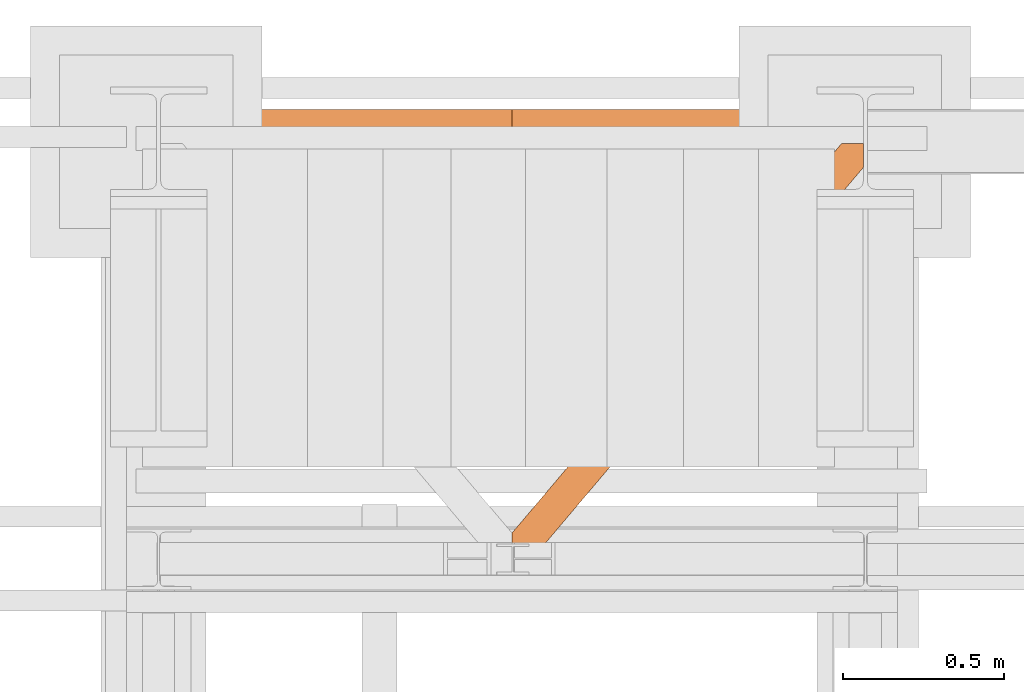
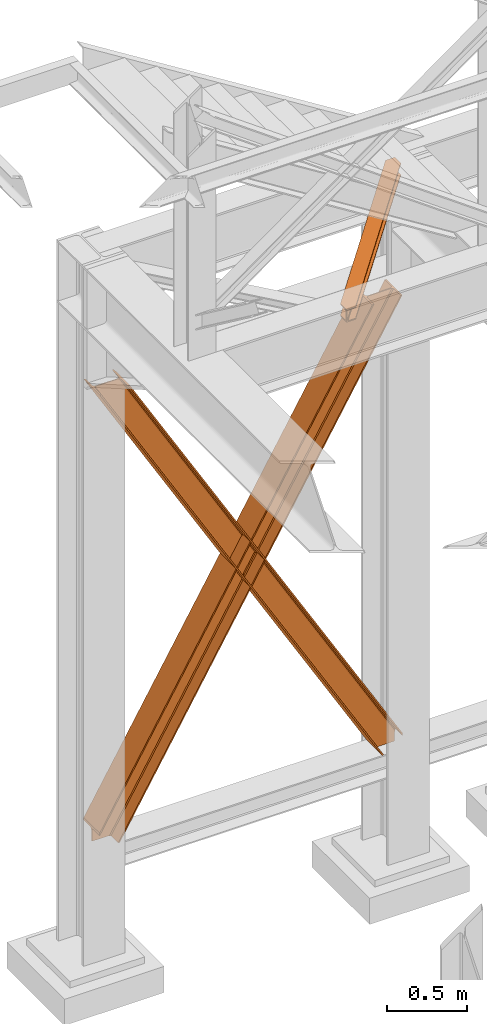
# One storey, part 134 of 208: 3 proxies.
"""IFC2X3 building model written with IfcOpenShell, lengths in millimetres."""

from ifc_helpers import new_model, entity, si_unit, converted_unit, frame, origin, origin_with_axes, place, context, subcontext, project, spatial, faceted_brep, element, save


model = new_model("IFC2X3")

# Units and contexts
model_context = context("Model", 3, precision=1e-05, world=origin())
plan_context = context("Plan", 3, precision=1e-05, world=origin())
body_context = subcontext(model_context, "Body", "Model", "MODEL_VIEW")
ifc_project = project(units=[si_unit("LENGTHUNIT", "METRE", prefix="MILLI"), converted_unit("PLANEANGLEUNIT", "DEGREE", entity("IfcPlaneAngleMeasure", 0.0174532925199433), si_unit("PLANEANGLEUNIT", "RADIAN"), dimensions=[0, 0, 0, 0, 0, 0, 0]), si_unit("AREAUNIT", "SQUARE_METRE"), si_unit("VOLUMEUNIT", "CUBIC_METRE")], contexts=[model_context, plan_context])

# Building, storey
building_placement = place(None, origin())
building = spatial("IfcBuilding", under=ifc_project, at=building_placement, CompositionType="COMPLEX")
storey_placement = place(building_placement, origin_with_axes())
storey = spatial("IfcBuildingStorey", under=building, at=storey_placement, Name="Geschoss", CompositionType="ELEMENT")

# Proxies
proxy_1_placement = place(storey_placement, frame((-3300.167549460099, -12562.57439501764, 734.9900149335328), z_axis=(0.0, 0.0, 1.0), x_axis=(1.0, 0.0, 0.0)))
element("IfcBuildingElementProxy", 1, at=proxy_1_placement, inside=storey, context=body_context, shape_type="Brep", body=[
    faceted_brep([(2187.432517936612, 0.01000000000021828, 120.8497915510924), (216.8471928951321, 0.01000000000021828, 3468.009977913908), (216.8471928951321, 200.0100029802325, 3468.009977913908), (2187.432517936612, 200.0100029802325, 120.8497915510924), (2187.432517936612, 200.0100029802325, 120.8497915510924), (216.8471928951321, 200.0100029802325, 3468.009977913908), (205.4347121912169, 200.0100029802325, 3468.009977913908), (2187.432517936612, 200.0100029802325, 101.4682129393398), (2187.432517936612, 200.0100029802325, 101.4682129393398), (205.4347121912169, 200.0100029802325, 3468.009977913908), (205.4347036882541, 121.2600035762789, 3468.009977913908), (2187.432517936951, 121.2600035762789, 101.4681984983711), (2187.432517936951, 121.2600035762789, 101.4681984983711), (205.4347036882541, 121.2600035762789, 3468.009977913908), (203.306794806967, 111.9441915473344, 3468.009977913909), (2187.432602958225, 111.9441915473344, 97.85427409430258), (2187.432602958225, 111.9441915473344, 97.85427409430258), (203.306794806967, 111.9441915473344, 3468.009977913909), (195.5238886772499, 105.1245498640838, 3468.009977913908), (2187.432517936612, 105.1245498640838, 84.63689245399041), (2187.432517936612, 105.1245498640838, 84.63689245399041), (195.5238886772499, 105.1245498640838, 3468.009977913908), (184.892235020021, 103.2600015571716, 3468.009977913908), (2187.432517936612, 103.2600015571716, 66.58142866151923), (2187.432517936612, 103.2600015571716, 0.009999999999990905), (2187.432517936612, 103.2600015571716, 66.58142866151923), (184.892235020021, 103.2600015571716, 3468.009977913908), (31.96494937214857, 103.2600015571716, 3468.009977913908), (2073.723887154785, 103.2600015571716, 0.01000000000021828), (2073.723887154785, 103.2600015571716, 0.01000000000021828), (31.96494937214857, 103.2600015571716, 3468.009977913908), (21.33329571491913, 105.1245498640838, 3468.009977913908), (2063.093996904378, 105.1245498640838, 0.01000000000010459), (2063.093996904378, 105.1245498640838, 0.01000000000010459), (21.33329571491913, 105.1245498640838, 3468.009977913908), (13.55038958520254, 111.9441915473344, 3468.009977913908), (2055.312379673187, 111.9441915473344, 0.009999999999763531), (2055.312379673187, 111.9441915473344, 0.009999999999763531), (13.55038958520254, 111.9441915473344, 3468.009977913908), (11.42248070391588, 121.2600035762789, 3468.009977913907), (2053.184822892689, 121.2600035762789, 0.009999999999763531), (2053.184822892689, 121.2600035762789, 0.009999999999763531), (11.42248070391588, 121.2600035762789, 3468.009977913907), (11.42248070391634, 200.0100029802325, 3468.009977913907), (2053.184822892689, 200.0100029802325, 0.009999999999763531), (2053.184822892689, 200.0100029802325, 0.009999999999763531), (11.42248070391634, 200.0100029802325, 3468.009977913907), (0.01000000000021828, 200.0100029802325, 3468.009977913908), (2041.774228435659, 200.0100029802325, 0.009999999999990905), (2041.774228435659, 200.0100029802325, 0.009999999999990905), (0.01000000000021828, 200.0100029802325, 3468.009977913908), (0.01000000000021828, 0.01000000000021828, 3468.009977913908), (2041.774228435659, 0.01000000000021828, 0.009999999999990905), (2041.774228435659, 0.01000000000021828, 0.009999999999990905), (0.01000000000021828, 0.01000000000021828, 3468.009977913908), (11.42248070391679, 0.01000000000021828, 3468.009977913908), (2053.184822892689, 0.01000000000021828, 0.009999999999877218), (2053.184822892689, 0.01000000000021828, 0.009999999999877218), (11.42248070391679, 0.01000000000021828, 3468.009977913908), (11.42248070391634, 78.75999940395377, 3468.009977913907), (2053.184822892689, 78.75999940395377, 0.009999999999763531), (2053.184822892689, 78.75999940395377, 0.009999999999763531), (11.42248070391634, 78.75999940395377, 3468.009977913907), (13.55038958520254, 88.07581143290008, 3468.009977913908), (2055.312379673187, 88.07581143289826, 0.009999999999763531), (2055.312379673187, 88.07581143289826, 0.009999999999763531), (13.55038958520254, 88.07581143290008, 3468.009977913908), (21.33329571491913, 94.89545311614893, 3468.009977913908), (2063.093996904379, 94.89545311614893, 0.009999999999763531), (2063.093996904379, 94.89545311614893, 0.009999999999763531), (21.33329571491913, 94.89545311614893, 3468.009977913908), (31.96494937214857, 96.76000142306111, 3468.009977913908), (2073.723887154785, 96.76000142306111, 0.01000000000021828), (2073.723887154785, 96.76000142306111, 0.01000000000021828), (31.96494937214857, 96.76000142306111, 3468.009977913908), (184.892235020021, 96.76000142306111, 3468.009977913908), (2187.432517936612, 96.76000142306111, 66.58142866151888), (2187.432517936612, 96.76000142306111, 0.009999999999990905), (2187.432517936612, 96.76000142306111, 66.58142866151888), (184.892235020021, 96.76000142306111, 3468.009977913908), (195.5238886772499, 94.89545311614893, 3468.009977913908), (2187.432517936612, 94.89545311615075, 84.63689245399041), (2187.432517936612, 94.89545311615075, 84.63689245399041), (195.5238886772499, 94.89545311614893, 3468.009977913908), (203.306794806967, 88.07581143289826, 3468.009977913909), (2187.432517936612, 88.07581143289826, 97.85441850857092), (2187.432517936612, 88.07581143289826, 97.85441850857092), (203.306794806967, 88.07581143289826, 3468.009977913909), (205.4347036882546, 78.75999940395377, 3468.009977913908), (2187.432433072335, 78.75999940395377, 101.4683426459951), (2187.432433072335, 78.75999940395377, 101.4683426459951), (205.4347036882546, 78.75999940395377, 3468.009977913908), (205.4347121912169, 0.01000000000021828, 3468.009977913908), (2187.432517936272, 0.01000000000021828, 101.4682129399164), (2187.432517936272, 0.01000000000021828, 101.4682129399164), (205.4347121912169, 0.01000000000021828, 3468.009977913908), (216.8471928951321, 0.01000000000021828, 3468.009977913908), (2187.432517936612, 0.01000000000021828, 120.8497915510924), (216.8471928951321, 0.01000000000021828, 3468.009977913908), (205.4347121912169, 0.01000000000021828, 3468.009977913908), (205.4347036882546, 78.75999940395377, 3468.009977913908), (203.306794806967, 88.07581143289826, 3468.009977913909), (195.5238886772499, 94.89545311614893, 3468.009977913908), (184.892235020021, 96.76000142306111, 3468.009977913908), (31.96494937214857, 96.76000142306111, 3468.009977913908), (21.33329571491913, 94.89545311614893, 3468.009977913908), (13.55038958520254, 88.07581143290008, 3468.009977913908), (11.42248070391634, 78.75999940395377, 3468.009977913907), (11.42248070391679, 0.01000000000021828, 3468.009977913908), (0.01000000000021828, 0.01000000000021828, 3468.009977913908), (0.01000000000021828, 200.0100029802325, 3468.009977913908), (11.42248070391634, 200.0100029802325, 3468.009977913907), (11.42248070391588, 121.2600035762789, 3468.009977913907), (13.55038958520254, 111.9441915473344, 3468.009977913908), (21.33329571491913, 105.1245498640838, 3468.009977913908), (31.96494937214857, 103.2600015571716, 3468.009977913908), (184.892235020021, 103.2600015571716, 3468.009977913908), (195.5238886772499, 105.1245498640838, 3468.009977913908), (203.306794806967, 111.9441915473344, 3468.009977913909), (205.4347036882541, 121.2600035762789, 3468.009977913908), (205.4347121912169, 200.0100029802325, 3468.009977913908), (216.8471928951321, 200.0100029802325, 3468.009977913908), (2187.432517936612, 96.76000142306111, 0.009999999999990905), (2187.432517936612, 96.76000142306111, 66.58142866151888), (2187.432517936612, 94.89545311615075, 84.63689245399041), (2187.432517936612, 88.07581143289826, 97.85441850857092), (2187.432433072335, 78.75999940395377, 101.4683426459951), (2187.432517936272, 0.01000000000021828, 101.4682129399164), (2187.432517936612, 0.01000000000021828, 120.8497915510924), (2187.432517936612, 200.0100029802325, 120.8497915510924), (2187.432517936612, 200.0100029802325, 101.4682129393398), (2187.432517936951, 121.2600035762789, 101.4681984983711), (2187.432602958225, 111.9441915473344, 97.85427409430258), (2187.432517936612, 105.1245498640838, 84.63689245399041), (2187.432517936612, 103.2600015571716, 66.58142866151923), (2187.432517936612, 103.2600015571716, 0.009999999999990905), (2073.723887154785, 103.2600015571716, 0.01000000000021828), (2063.093996904378, 105.1245498640838, 0.01000000000010459), (2055.312379673187, 111.9441915473344, 0.009999999999763531), (2053.184822892689, 121.2600035762789, 0.009999999999763531), (2053.184822892689, 200.0100029802325, 0.009999999999763531), (2041.774228435659, 200.0100029802325, 0.009999999999990905), (2041.774228435659, 0.01000000000021828, 0.009999999999990905), (2053.184822892689, 0.01000000000021828, 0.009999999999877218), (2053.184822892689, 78.75999940395377, 0.009999999999763531), (2055.312379673187, 88.07581143289826, 0.009999999999763531), (2063.093996904379, 94.89545311614893, 0.009999999999763531), (2073.723887154785, 96.76000142306111, 0.01000000000021828), (2187.432517936612, 96.76000142306111, 0.009999999999990905), (2187.432517936612, 103.2600015571716, 0.009999999999990905)], [[[0, 1, 2, 3]], [[4, 5, 6, 7]], [[8, 9, 10, 11]], [[12, 13, 14, 15]], [[16, 17, 18, 19]], [[20, 21, 22, 23]], [[24, 25, 26, 27, 28]], [[29, 30, 31, 32]], [[33, 34, 35, 36]], [[37, 38, 39, 40]], [[41, 42, 43, 44]], [[45, 46, 47, 48]], [[49, 50, 51, 52]], [[53, 54, 55, 56]], [[57, 58, 59, 60]], [[61, 62, 63, 64]], [[65, 66, 67, 68]], [[69, 70, 71, 72]], [[73, 74, 75, 76, 77]], [[78, 79, 80, 81]], [[82, 83, 84, 85]], [[86, 87, 88, 89]], [[90, 91, 92, 93]], [[94, 95, 96, 97]], [[98, 99, 100, 101, 102, 103, 104, 105, 106, 107, 108, 109, 110, 111, 112, 113, 114, 115, 116, 117, 118, 119, 120, 121]], [[122, 123, 124, 125, 126, 127, 128, 129, 130, 131, 132, 133, 134, 135]], [[136, 137, 138, 139, 140, 141, 142, 143, 144, 145, 146, 147, 148, 149]]], orient=[[False], [False], [False], [False], [False], [False], [False], [False], [False], [False], [False], [False], [False], [False], [False], [False], [False], [False], [False], [False], [False], [False], [False], [False], [False], [False], [False]]),
])
proxy_2_placement = place(storey_placement, frame((-3300.745116440791, -12562.57439501764, 734.9900149335328), z_axis=(0.0, 0.0, 1.0), x_axis=(1.0, 0.0, 0.0)))
element("IfcBuildingElementProxy", 2, at=proxy_2_placement, inside=storey, context=body_context, shape_type="Brep", body=[
    faceted_brep([(0.01008502161403158, 0.01000000000021828, 120.8497915510924), (0.01008502161403158, 200.0100029802325, 120.8497915510924), (1970.595410063094, 200.0100029802325, 3468.009977913908), (1970.595410063094, 0.01000000000021828, 3468.009977913908), (0.01008502161403158, 200.0100029802325, 120.8497915510924), (0.01008502161357683, 200.0100029802325, 101.4682129393398), (1982.007890767009, 200.0100029802325, 3468.009977913908), (1970.595410063094, 200.0100029802325, 3468.009977913908), (0.01008502161357683, 200.0100029802325, 101.4682129393398), (0.01008502127479005, 121.2600035762789, 101.4681984983711), (1982.007899269972, 121.2600035762789, 3468.009977913908), (1982.007890767009, 200.0100029802325, 3468.009977913908), (0.01008502127479005, 121.2600035762789, 101.4681984983711), (0.01000000000021828, 111.9441915473344, 97.85427409430258), (1984.135808151259, 111.9441915473344, 3468.009977913909), (1982.007899269972, 121.2600035762789, 3468.009977913908), (0.01000000000021828, 111.9441915473344, 97.85427409430258), (0.01008502161403158, 105.1245498640838, 84.63689245399041), (1991.918714280976, 105.1245498640838, 3468.009977913908), (1984.135808151259, 111.9441915473344, 3468.009977913909), (0.01008502161403158, 105.1245498640838, 84.63689245399041), (0.01008502161403158, 103.2600015571716, 66.58142866151923), (2002.550367938205, 103.2600015571716, 3468.009977913908), (1991.918714280976, 105.1245498640838, 3468.009977913908), (0.01008502161403158, 103.2600015571716, 0.009999999999990905), (113.7187158034403, 103.2600015571716, 0.01000000000021828), (2155.477653586077, 103.2600015571716, 3468.009977913908), (2002.550367938205, 103.2600015571716, 3468.009977913908), (0.01008502161403158, 103.2600015571716, 66.58142866151923), (113.7187158034403, 103.2600015571716, 0.01000000000021828), (124.3486060538471, 105.1245498640838, 0.01000000000010459), (2166.109307243307, 105.1245498640838, 3468.009977913908), (2155.477653586077, 103.2600015571716, 3468.009977913908), (124.3486060538471, 105.1245498640838, 0.01000000000010459), (132.1302232850385, 111.9441915473344, 0.009999999999763531), (2173.892213373023, 111.9441915473344, 3468.009977913908), (2166.109307243307, 105.1245498640838, 3468.009977913908), (132.1302232850385, 111.9441915473344, 0.009999999999763531), (134.2577800655372, 121.2600035762789, 0.009999999999763531), (2176.02012225431, 121.2600035762789, 3468.009977913907), (2173.892213373023, 111.9441915473344, 3468.009977913908), (134.2577800655372, 121.2600035762789, 0.009999999999763531), (134.2577800655372, 200.0100029802325, 0.009999999999763531), (2176.020122254309, 200.0100029802325, 3468.009977913907), (2176.02012225431, 121.2600035762789, 3468.009977913907), (134.2577800655372, 200.0100029802325, 0.009999999999763531), (145.6683745225669, 200.0100029802325, 0.009999999999990905), (2187.432602958225, 200.0100029802325, 3468.009977913908), (2176.020122254309, 200.0100029802325, 3468.009977913907), (145.6683745225669, 200.0100029802325, 0.009999999999990905), (145.6683745225669, 0.01000000000021828, 0.009999999999990905), (2187.432602958225, 0.01000000000021828, 3468.009977913908), (2187.432602958225, 200.0100029802325, 3468.009977913908), (145.6683745225669, 0.01000000000021828, 0.009999999999990905), (134.2577800655372, 0.01000000000021828, 0.009999999999877218), (2176.020122254309, 0.01000000000021828, 3468.009977913908), (2187.432602958225, 0.01000000000021828, 3468.009977913908), (134.2577800655372, 0.01000000000021828, 0.009999999999877218), (134.2577800655372, 78.75999940395377, 0.009999999999763531), (2176.020122254309, 78.75999940395377, 3468.009977913907), (2176.020122254309, 0.01000000000021828, 3468.009977913908), (134.2577800655372, 78.75999940395377, 0.009999999999763531), (132.1302232850385, 88.07581143289826, 0.009999999999763531), (2173.892213373023, 88.07581143290008, 3468.009977913908), (2176.020122254309, 78.75999940395377, 3468.009977913907), (132.1302232850385, 88.07581143289826, 0.009999999999763531), (124.3486060538467, 94.89545311614893, 0.009999999999763531), (2166.109307243307, 94.89545311614893, 3468.009977913908), (2173.892213373023, 88.07581143290008, 3468.009977913908), (124.3486060538467, 94.89545311614893, 0.009999999999763531), (113.7187158034403, 96.76000142306111, 0.01000000000021828), (2155.477653586077, 96.76000142306111, 3468.009977913908), (2166.109307243307, 94.89545311614893, 3468.009977913908), (113.7187158034403, 96.76000142306111, 0.01000000000021828), (0.01008502161357683, 96.76000142306111, 0.009999999999990905), (0.01008502161403158, 96.76000142306111, 66.58142866151888), (2002.550367938205, 96.76000142306111, 3468.009977913908), (2155.477653586077, 96.76000142306111, 3468.009977913908), (0.01008502161403158, 96.76000142306111, 66.58142866151888), (0.01008502161403158, 94.89545311615075, 84.63689245399041), (1991.918714280976, 94.89545311614893, 3468.009977913908), (2002.550367938205, 96.76000142306111, 3468.009977913908), (0.01008502161403158, 94.89545311615075, 84.63689245399041), (0.01008502161403158, 88.07581143289826, 97.85441850857092), (1984.135808151259, 88.07581143289826, 3468.009977913909), (1991.918714280976, 94.89545311614893, 3468.009977913908), (0.01008502161403158, 88.07581143289826, 97.85441850857092), (0.01016988589071843, 78.75999940395377, 101.4683426459951), (1982.007899269972, 78.75999940395377, 3468.009977913908), (1984.135808151259, 88.07581143289826, 3468.009977913909), (0.01016988589071843, 78.75999940395377, 101.4683426459951), (0.0100850219532731, 0.01000000000021828, 101.4682129399164), (1982.007890767009, 0.01000000000021828, 3468.009977913908), (1982.007899269972, 78.75999940395377, 3468.009977913908), (0.0100850219532731, 0.01000000000021828, 101.4682129399164), (0.01008502161403158, 0.01000000000021828, 120.8497915510924), (1970.595410063094, 0.01000000000021828, 3468.009977913908), (1982.007890767009, 0.01000000000021828, 3468.009977913908), (1970.595410063094, 0.01000000000021828, 3468.009977913908), (1970.595410063094, 200.0100029802325, 3468.009977913908), (1982.007890767009, 200.0100029802325, 3468.009977913908), (1982.007899269972, 121.2600035762789, 3468.009977913908), (1984.135808151259, 111.9441915473344, 3468.009977913909), (1991.918714280976, 105.1245498640838, 3468.009977913908), (2002.550367938205, 103.2600015571716, 3468.009977913908), (2155.477653586077, 103.2600015571716, 3468.009977913908), (2166.109307243307, 105.1245498640838, 3468.009977913908), (2173.892213373023, 111.9441915473344, 3468.009977913908), (2176.02012225431, 121.2600035762789, 3468.009977913907), (2176.020122254309, 200.0100029802325, 3468.009977913907), (2187.432602958225, 200.0100029802325, 3468.009977913908), (2187.432602958225, 0.01000000000021828, 3468.009977913908), (2176.020122254309, 0.01000000000021828, 3468.009977913908), (2176.020122254309, 78.75999940395377, 3468.009977913907), (2173.892213373023, 88.07581143290008, 3468.009977913908), (2166.109307243307, 94.89545311614893, 3468.009977913908), (2155.477653586077, 96.76000142306111, 3468.009977913908), (2002.550367938205, 96.76000142306111, 3468.009977913908), (1991.918714280976, 94.89545311614893, 3468.009977913908), (1984.135808151259, 88.07581143289826, 3468.009977913909), (1982.007899269972, 78.75999940395377, 3468.009977913908), (1982.007890767009, 0.01000000000021828, 3468.009977913908), (0.01008502161357683, 96.76000142306111, 0.009999999999990905), (0.01008502161403158, 103.2600015571716, 0.009999999999990905), (0.01008502161403158, 103.2600015571716, 66.58142866151923), (0.01008502161403158, 105.1245498640838, 84.63689245399041), (0.01000000000021828, 111.9441915473344, 97.85427409430258), (0.01008502127479005, 121.2600035762789, 101.4681984983711), (0.01008502161357683, 200.0100029802325, 101.4682129393398), (0.01008502161403158, 200.0100029802325, 120.8497915510924), (0.01008502161403158, 0.01000000000021828, 120.8497915510924), (0.0100850219532731, 0.01000000000021828, 101.4682129399164), (0.01016988589071843, 78.75999940395377, 101.4683426459951), (0.01008502161403158, 88.07581143289826, 97.85441850857092), (0.01008502161403158, 94.89545311615075, 84.63689245399041), (0.01008502161403158, 96.76000142306111, 66.58142866151888), (113.7187158034403, 103.2600015571716, 0.01000000000021828), (0.01008502161403158, 103.2600015571716, 0.009999999999990905), (0.01008502161357683, 96.76000142306111, 0.009999999999990905), (113.7187158034403, 96.76000142306111, 0.01000000000021828), (124.3486060538467, 94.89545311614893, 0.009999999999763531), (132.1302232850385, 88.07581143289826, 0.009999999999763531), (134.2577800655372, 78.75999940395377, 0.009999999999763531), (134.2577800655372, 0.01000000000021828, 0.009999999999877218), (145.6683745225669, 0.01000000000021828, 0.009999999999990905), (145.6683745225669, 200.0100029802325, 0.009999999999990905), (134.2577800655372, 200.0100029802325, 0.009999999999763531), (134.2577800655372, 121.2600035762789, 0.009999999999763531), (132.1302232850385, 111.9441915473344, 0.009999999999763531), (124.3486060538471, 105.1245498640838, 0.01000000000010459)], [[[0, 1, 2, 3]], [[4, 5, 6, 7]], [[8, 9, 10, 11]], [[12, 13, 14, 15]], [[16, 17, 18, 19]], [[20, 21, 22, 23]], [[24, 25, 26, 27, 28]], [[29, 30, 31, 32]], [[33, 34, 35, 36]], [[37, 38, 39, 40]], [[41, 42, 43, 44]], [[45, 46, 47, 48]], [[49, 50, 51, 52]], [[53, 54, 55, 56]], [[57, 58, 59, 60]], [[61, 62, 63, 64]], [[65, 66, 67, 68]], [[69, 70, 71, 72]], [[73, 74, 75, 76, 77]], [[78, 79, 80, 81]], [[82, 83, 84, 85]], [[86, 87, 88, 89]], [[90, 91, 92, 93]], [[94, 95, 96, 97]], [[98, 99, 100, 101, 102, 103, 104, 105, 106, 107, 108, 109, 110, 111, 112, 113, 114, 115, 116, 117, 118, 119, 120, 121]], [[122, 123, 124, 125, 126, 127, 128, 129, 130, 131, 132, 133, 134, 135]], [[136, 137, 138, 139, 140, 141, 142, 143, 144, 145, 146, 147, 148, 149]]], orient=[[False], [False], [False], [False], [False], [False], [False], [False], [False], [False], [False], [False], [False], [False], [False], [False], [False], [False], [False], [False], [False], [False], [False], [False], [False], [False], [False]]),
])
proxy_3_placement = place(storey_placement, frame((-2206.745031471333, -13757.87439038569, 5101.99001616488), z_axis=(0.0, 0.0, 1.0), x_axis=(1.0, 0.0, 0.0)))
element("IfcBuildingElementProxy", 3, at=proxy_3_placement, inside=storey, context=body_context, shape_type="Brep", body=[
    faceted_brep([(65.5076408449404, 0.00999999999839929, 8.010001311303313), (1094.009999947835, 1215.512788030694, 8.010001311302403), (1094.009999947835, 1215.512788030694, 0.01000000000112777), (65.5076408449404, 0.00999999999839929, 0.01000000000112777), (65.5076408449404, 0.00999999999839929, 0.01000000000112777), (1094.009999947835, 1215.512788030694, 0.01000000000112777), (1094.009999947835, 1290.610003345229, 0.01000000000021828), (1026.558515831797, 1290.610003345229, 0.01000000000021828), (0.01000000000385626, 77.41630281674588, 0.01000000000112777), (0.01000000000385626, 0.00999999999839929, 0.01000000000112777), (0.01000000000385626, 77.41630281674588, 0.01000000000112777), (1026.558515831797, 1290.610003345229, 0.01000000000021828), (1026.558515831797, 1290.610003345229, 8.010001311303313), (0.01000000000203727, 77.41630281674588, 8.010001311303313), (0.01000000000203727, 77.41630281674588, 8.010001311303313), (1026.558515831797, 1290.610003345229, 8.010001311303313), (1073.061840441307, 1290.610003345229, 8.010001311303313), (0.01000000000385626, 22.45782827823496, 8.010001311303313), (0.01000000000385626, 22.45782827823496, 8.010001311303313), (1073.061840441307, 1290.610003345229, 8.010001311303313), (1081.197355239432, 1290.610003345229, 9.253033826352294), (0.01000000000385626, 12.84312897135897, 9.253033826352294), (0.01000000000385626, 12.84312897135897, 9.253033826352294), (1081.197355239432, 1290.610003345229, 9.253033826352294), (1087.152961141163, 1290.610003345229, 13.79946006298178), (0.01000000000385626, 5.804685632949258, 13.79946006298178), (0.01000000000385626, 5.804685632949258, 13.79946006298178), (1087.152961141163, 1290.610003345229, 13.79946006298178), (1088.781274451489, 1290.610003345229, 20.01000141561144), (0.01000000000385626, 3.880315357109794, 20.01000141561144), (0.01000000000385626, 3.880315357109794, 20.01000141561144), (1088.781274451489, 1290.610003345229, 20.01000141561144), (1088.781274451489, 1290.610003345229, 76.01000128150099), (0.01000000000385626, 3.880315357109794, 76.01000128150099), (0.01000000000385626, 3.880315357109794, 76.01000128150099), (1088.781274451489, 1290.610003345229, 76.01000128150099), (1087.152961141163, 1290.610003345229, 82.2205407714855), (0.01000000000385626, 5.804685632949258, 82.2205407714855), (0.01000000000385626, 5.804685632949258, 82.2205407714855), (1087.152961141163, 1290.610003345229, 82.2205407714855), (1081.197355239432, 1290.610003345229, 86.76696700811499), (0.01000000000385626, 12.84312897135897, 86.76696700811499), (0.01000000000385626, 12.84312897135897, 86.76696700811499), (1081.197355239432, 1290.610003345229, 86.76696700811499), (1073.061840441305, 1290.610003345229, 88.00999952316397), (0.01000000000385626, 22.45782827823496, 88.00999952316397), (0.01000000000385626, 22.45782827823496, 88.00999952316397), (1073.061840441305, 1290.610003345229, 88.00999952316397), (1026.558515831797, 1290.610003345229, 88.00999952316397), (0.01000000000385626, 77.41630281674588, 88.00999952316397), (0.01000000000385626, 77.41630281674588, 88.00999952316397), (1026.558515831797, 1290.610003345229, 88.00999952316397), (1026.558515831797, 1290.610003345229, 96.01000083446615), (0.01000000000021828, 77.41630281674406, 96.01000083446615), (0.01000000000021828, 77.41630281674406, 96.01000083446615), (1026.558515831797, 1290.610003345229, 96.01000083446615), (1094.009999947835, 1290.610003345229, 96.01000083446615), (1094.009999947835, 1215.512788030694, 96.01000083446615), (65.5076408449404, 0.00999999999839929, 96.01000083446615), (0.01000000000203727, 0.00999999999839929, 96.01000083446615), (65.5076408449404, 0.00999999999839929, 96.01000083446615), (1094.009999947835, 1215.512788030694, 96.01000083446615), (1094.009999947835, 1215.512788030694, 88.00999952316397), (65.5076408449404, 0.00999999999839929, 88.00999952316397), (65.5076408449404, 0.00999999999839929, 88.00999952316397), (1094.009999947835, 1215.512788030694, 88.00999952316397), (1094.009999947835, 1270.471262569206, 88.00999952316397), (19.00431623542863, 0.00999999999839929, 88.00999952316397), (19.00431623542863, 0.00999999999839929, 88.00999952316397), (1094.009999947835, 1270.471262569206, 88.00999952316397), (1094.009999947835, 1280.085961876082, 86.76696700811499), (10.86880143730195, 0.00999999999839929, 86.76696700811499), (10.86880143730195, 0.00999999999839929, 86.76696700811499), (1094.009999947835, 1280.085961876082, 86.76696700811499), (1094.009999947835, 1287.124405214488, 82.2205407714855), (4.913195535573323, 0.00999999999839929, 82.2205407714855), (4.913195535573323, 0.00999999999839929, 82.2205407714855), (1094.009999947835, 1287.124405214488, 82.2205407714855), (1094.009999947835, 1289.048775490332, 76.01000128150099), (3.284882225247202, 0.00999999999839929, 76.01000128150099), (3.284882225247202, 0.00999999999839929, 76.01000128150099), (1094.009999947835, 1289.048775490332, 76.01000128150099), (1094.009999947835, 1289.048775490332, 20.01000141561144), (3.284882225247202, 0.00999999999839929, 20.01000141561144), (3.284882225247202, 0.00999999999839929, 20.01000141561144), (1094.009999947835, 1289.048775490332, 20.01000141561144), (1094.009999947835, 1287.12440521449, 13.79946006298178), (4.913195535573323, 0.00999999999839929, 13.79946006298178), (4.913195535573323, 0.00999999999839929, 13.79946006298178), (1094.009999947835, 1287.12440521449, 13.79946006298178), (1094.009999947835, 1280.085961876081, 9.253033826352294), (10.86880143730377, 0.00999999999839929, 9.253033826352294), (10.86880143730377, 0.00999999999839929, 9.253033826352294), (1094.009999947835, 1280.085961876081, 9.253033826352294), (1094.009999947835, 1270.471262569206, 8.010001311303313), (19.00431623543045, 0.00999999999839929, 8.010001311303313), (19.00431623543045, 0.00999999999839929, 8.010001311303313), (1094.009999947835, 1270.471262569206, 8.010001311303313), (1094.009999947835, 1215.512788030694, 8.010001311302403), (65.5076408449404, 0.00999999999839929, 8.010001311303313), (0.01000000000385626, 77.41630281674588, 0.01000000000112777), (0.01000000000203727, 77.41630281674588, 8.010001311303313), (0.01000000000385626, 22.45782827823496, 8.010001311303313), (0.01000000000385626, 12.84312897135897, 9.253033826352294), (0.01000000000385626, 5.804685632949258, 13.79946006298178), (0.01000000000385626, 3.880315357109794, 20.01000141561144), (0.01000000000385626, 3.880315357109794, 76.01000128150099), (0.01000000000385626, 5.804685632949258, 82.2205407714855), (0.01000000000385626, 12.84312897135897, 86.76696700811499), (0.01000000000385626, 22.45782827823496, 88.00999952316397), (0.01000000000385626, 77.41630281674588, 88.00999952316397), (0.01000000000021828, 77.41630281674406, 96.01000083446615), (0.01000000000203727, 0.00999999999839929, 96.01000083446615), (0.01000000000385626, 0.00999999999839929, 0.01000000000112777), (0.01000000000203727, 0.00999999999839929, 96.01000083446615), (65.5076408449404, 0.00999999999839929, 96.01000083446615), (65.5076408449404, 0.00999999999839929, 88.00999952316397), (19.00431623542863, 0.00999999999839929, 88.00999952316397), (10.86880143730195, 0.00999999999839929, 86.76696700811499), (4.913195535573323, 0.00999999999839929, 82.2205407714855), (3.284882225247202, 0.00999999999839929, 76.01000128150099), (3.284882225247202, 0.00999999999839929, 20.01000141561144), (4.913195535573323, 0.00999999999839929, 13.79946006298178), (10.86880143730377, 0.00999999999839929, 9.253033826352294), (19.00431623543045, 0.00999999999839929, 8.010001311303313), (65.5076408449404, 0.00999999999839929, 8.010001311303313), (65.5076408449404, 0.00999999999839929, 0.01000000000112777), (0.01000000000385626, 0.00999999999839929, 0.01000000000112777), (1094.009999947835, 1215.512788030694, 8.010001311302403), (1094.009999947835, 1270.471262569206, 8.010001311303313), (1094.009999947835, 1280.085961876081, 9.253033826352294), (1094.009999947835, 1287.12440521449, 13.79946006298178), (1094.009999947835, 1289.048775490332, 20.01000141561144), (1094.009999947835, 1289.048775490332, 76.01000128150099), (1094.009999947835, 1287.124405214488, 82.2205407714855), (1094.009999947835, 1280.085961876082, 86.76696700811499), (1094.009999947835, 1270.471262569206, 88.00999952316397), (1094.009999947835, 1215.512788030694, 88.00999952316397), (1094.009999947835, 1215.512788030694, 96.01000083446615), (1094.009999947835, 1290.610003345229, 96.01000083446615), (1094.009999947835, 1290.610003345229, 0.01000000000021828), (1094.009999947835, 1215.512788030694, 0.01000000000112777), (1094.009999947835, 1290.610003345229, 0.01000000000021828), (1094.009999947835, 1290.610003345229, 96.01000083446615), (1026.558515831797, 1290.610003345229, 96.01000083446615), (1026.558515831797, 1290.610003345229, 88.00999952316397), (1073.061840441305, 1290.610003345229, 88.00999952316397), (1081.197355239432, 1290.610003345229, 86.76696700811499), (1087.152961141163, 1290.610003345229, 82.2205407714855), (1088.781274451489, 1290.610003345229, 76.01000128150099), (1088.781274451489, 1290.610003345229, 20.01000141561144), (1087.152961141163, 1290.610003345229, 13.79946006298178), (1081.197355239432, 1290.610003345229, 9.253033826352294), (1073.061840441307, 1290.610003345229, 8.010001311303313), (1026.558515831797, 1290.610003345229, 8.010001311303313), (1026.558515831797, 1290.610003345229, 0.01000000000021828)], [[[0, 1, 2, 3]], [[4, 5, 6, 7, 8, 9]], [[10, 11, 12, 13]], [[14, 15, 16, 17]], [[18, 19, 20, 21]], [[22, 23, 24, 25]], [[26, 27, 28, 29]], [[30, 31, 32, 33]], [[34, 35, 36, 37]], [[38, 39, 40, 41]], [[42, 43, 44, 45]], [[46, 47, 48, 49]], [[50, 51, 52, 53]], [[54, 55, 56, 57, 58, 59]], [[60, 61, 62, 63]], [[64, 65, 66, 67]], [[68, 69, 70, 71]], [[72, 73, 74, 75]], [[76, 77, 78, 79]], [[80, 81, 82, 83]], [[84, 85, 86, 87]], [[88, 89, 90, 91]], [[92, 93, 94, 95]], [[96, 97, 98, 99]], [[100, 101, 102, 103, 104, 105, 106, 107, 108, 109, 110, 111, 112, 113]], [[114, 115, 116, 117, 118, 119, 120, 121, 122, 123, 124, 125, 126, 127]], [[128, 129, 130, 131, 132, 133, 134, 135, 136, 137, 138, 139, 140, 141]], [[142, 143, 144, 145, 146, 147, 148, 149, 150, 151, 152, 153, 154, 155]]], orient=[[False], [False], [False], [False], [False], [False], [False], [False], [False], [False], [False], [False], [False], [False], [False], [False], [False], [False], [False], [False], [False], [False], [False], [False], [False], [False], [False], [False]]),
])

save(model, "model.ifc")
